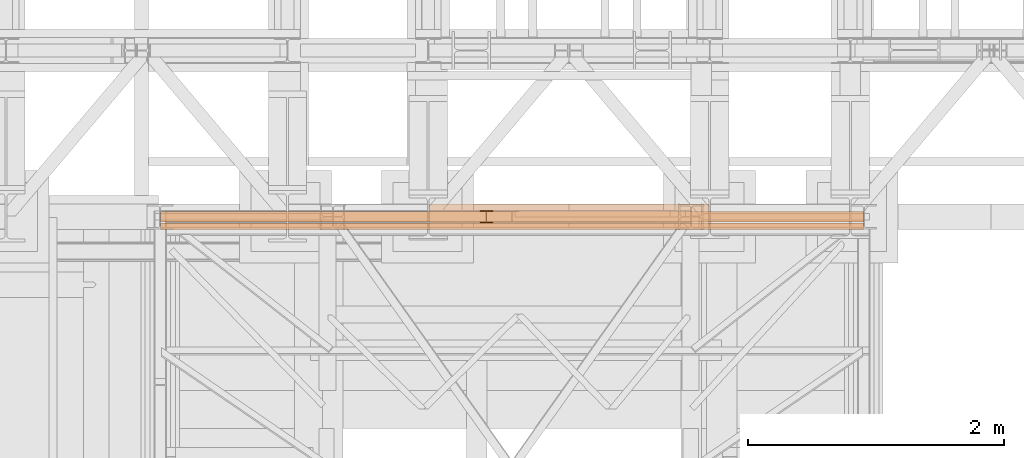
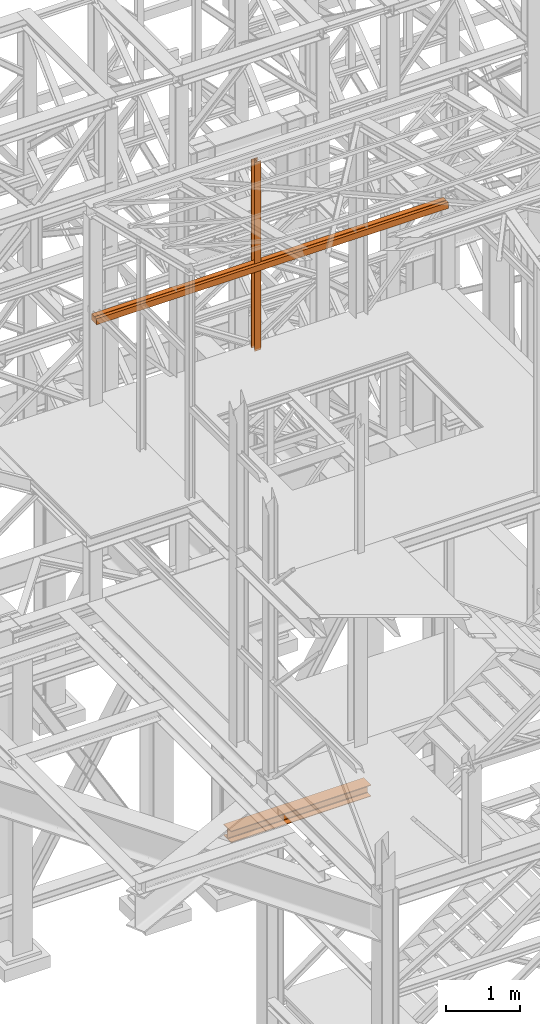
# One storey, part 70 of 208: 5 proxies.
"""IFC2X3 building model written with IfcOpenShell, lengths in millimetres."""

from ifc_helpers import new_model, entity, si_unit, converted_unit, frame, origin, origin_with_axes, place, context, subcontext, project, spatial, faceted_brep, element, save


model = new_model("IFC2X3")

# Units and contexts
model_context = context("Model", 3, precision=1e-05, world=origin())
plan_context = context("Plan", 3, precision=1e-05, world=origin())
body_context = subcontext(model_context, "Body", "Model", "MODEL_VIEW")
ifc_project = project(units=[si_unit("LENGTHUNIT", "METRE", prefix="MILLI"), converted_unit("PLANEANGLEUNIT", "DEGREE", entity("IfcPlaneAngleMeasure", 0.0174532925199433), si_unit("PLANEANGLEUNIT", "RADIAN"), dimensions=[0, 0, 0, 0, 0, 0, 0]), si_unit("AREAUNIT", "SQUARE_METRE"), si_unit("VOLUMEUNIT", "CUBIC_METRE")], contexts=[model_context, plan_context])

# Building, storey
building_placement = place(None, origin())
building = spatial("IfcBuilding", under=ifc_project, at=building_placement, CompositionType="COMPLEX")
storey_placement = place(building_placement, origin_with_axes())
storey = spatial("IfcBuildingStorey", under=building, at=storey_placement, Name="Geschoss", CompositionType="ELEMENT")

# Proxies
proxy_1_placement = place(storey_placement, frame((3698.25496852866, -17310.57439031789, 8484.990002086157), z_axis=(0.0, 0.0, 1.0), x_axis=(1.0, 0.0, 0.0)))
element("IfcBuildingElementProxy", 1, at=proxy_1_placement, inside=storey, context=body_context, shape_type="Brep", body=[
    faceted_brep([(100.010000000002, 88.0099999999984, 0.01000000000021828), (100.010000000002, 96.0099999999984, 0.01000000000021828), (0.01000000000203727, 96.0099999999984, 0.01000000000021828), (0.01000000000203727, 88.0099999999984, 0.01000000000021828), (47.51000000000204, 88.0099999999984, 0.01000000000021828), (47.51000000000204, 8.0099999999984, 0.01000000000021828), (0.01000000000203727, 8.0099999999984, 0.01000000000021828), (0.01000000000203727, 0.00999999999839929, 0.01000000000021828), (100.010000000002, 0.00999999999839929, 0.01000000000021828), (100.010000000002, 8.0099999999984, 0.01000000000021828), (52.51000000000204, 8.0099999999984, 0.01000000000021828), (52.51000000000204, 88.0099999999984, 0.01000000000021828), (100.010000000002, 96.0099999999984, 0.01000000000021828), (100.010000000002, 88.0099999999984, 0.01000000000021828), (100.0100000000002, 88.0099999999984, 3115.009992251404), (100.0100000000002, 96.0099999999984, 3115.009992251404), (0.01000000000203727, 96.0099999999984, 0.01000000000021828), (100.010000000002, 96.0099999999984, 0.01000000000021828), (100.0100000000002, 96.0099999999984, 3115.009992251404), (0.01000000000021828, 96.0099999999984, 3115.009992251404), (0.01000000000203727, 88.0099999999984, 0.01000000000021828), (0.01000000000203727, 96.0099999999984, 0.01000000000021828), (0.01000000000021828, 96.0099999999984, 3115.009992251404), (0.01000000000021828, 88.0099999999984, 3115.009992251404), (47.51000000000204, 88.0099999999984, 0.01000000000021828), (0.01000000000203727, 88.0099999999984, 0.01000000000021828), (0.01000000000021828, 88.0099999999984, 3115.009992251404), (47.51000000000022, 88.0099999999984, 3115.009992251404), (47.51000000000204, 8.0099999999984, 0.01000000000021828), (47.51000000000204, 88.0099999999984, 0.01000000000021828), (47.51000000000022, 88.0099999999984, 3115.009992251404), (47.51000000000022, 8.0099999999984, 3115.009992251404), (0.01000000000203727, 8.0099999999984, 0.01000000000021828), (47.51000000000204, 8.0099999999984, 0.01000000000021828), (47.51000000000022, 8.0099999999984, 3115.009992251404), (0.01000000000021828, 8.0099999999984, 3115.009992251404), (0.01000000000203727, 0.00999999999839929, 0.01000000000021828), (0.01000000000203727, 8.0099999999984, 0.01000000000021828), (0.01000000000021828, 8.0099999999984, 3115.009992251404), (0.01000000000021828, 0.00999999999839929, 3115.009992251404), (100.010000000002, 0.00999999999839929, 0.01000000000021828), (0.01000000000203727, 0.00999999999839929, 0.01000000000021828), (0.01000000000021828, 0.00999999999839929, 3115.009992251404), (100.0100000000002, 0.00999999999839929, 3115.009992251404), (100.010000000002, 8.0099999999984, 0.01000000000021828), (100.010000000002, 0.00999999999839929, 0.01000000000021828), (100.0100000000002, 0.00999999999839929, 3115.009992251404), (100.0100000000002, 8.0099999999984, 3115.009992251404), (52.51000000000204, 8.0099999999984, 0.01000000000021828), (100.010000000002, 8.0099999999984, 0.01000000000021828), (100.0100000000002, 8.0099999999984, 3115.009992251404), (52.51000000000022, 8.0099999999984, 3115.009992251404), (52.51000000000204, 88.0099999999984, 0.01000000000021828), (52.51000000000204, 8.0099999999984, 0.01000000000021828), (52.51000000000022, 8.0099999999984, 3115.009992251404), (52.51000000000022, 88.0099999999984, 3115.009992251404), (100.010000000002, 88.0099999999984, 0.01000000000021828), (52.51000000000204, 88.0099999999984, 0.01000000000021828), (52.51000000000022, 88.0099999999984, 3115.009992251404), (100.0100000000002, 88.0099999999984, 3115.009992251404), (100.0100000000002, 88.0099999999984, 3115.009992251404), (52.51000000000022, 88.0099999999984, 3115.009992251404), (52.51000000000022, 8.0099999999984, 3115.009992251404), (100.0100000000002, 8.0099999999984, 3115.009992251404), (100.0100000000002, 0.00999999999839929, 3115.009992251404), (0.01000000000021828, 0.00999999999839929, 3115.009992251404), (0.01000000000021828, 8.0099999999984, 3115.009992251404), (47.51000000000022, 8.0099999999984, 3115.009992251404), (47.51000000000022, 88.0099999999984, 3115.009992251404), (0.01000000000021828, 88.0099999999984, 3115.009992251404), (0.01000000000021828, 96.0099999999984, 3115.009992251404), (100.0100000000002, 96.0099999999984, 3115.009992251404)], [[[0, 1, 2, 3, 4, 5, 6, 7, 8, 9, 10, 11]], [[12, 13, 14, 15]], [[16, 17, 18, 19]], [[20, 21, 22, 23]], [[24, 25, 26, 27]], [[28, 29, 30, 31]], [[32, 33, 34, 35]], [[36, 37, 38, 39]], [[40, 41, 42, 43]], [[44, 45, 46, 47]], [[48, 49, 50, 51]], [[52, 53, 54, 55]], [[56, 57, 58, 59]], [[60, 61, 62, 63, 64, 65, 66, 67, 68, 69, 70, 71]]], orient=[[False], [False], [False], [False], [False], [False], [False], [False], [False], [False], [False], [False], [False], [False]]),
])
proxy_2_placement = place(storey_placement, frame((1201.504968595714, -17362.574391808, 9829.990000745052), z_axis=(0.0, 0.0, 1.0), x_axis=(1.0, 0.0, 0.0)))
element("IfcBuildingElementProxy", 2, at=proxy_2_placement, inside=storey, context=body_context, shape_type="Brep", body=[
    faceted_brep([(0.01000000000021828, 140.0100014901145, 0.01000000000021828), (0.01000000000021828, 60.01000149011452, 0.01000000000021828), (0.01000000000021828, 60.01000149011452, 47.51000000000022), (0.01000000000021828, 140.0100014901145, 47.51000000000022), (0.01000000000021828, 52.01000149011452, 0.01000000000021828), (0.01000000000021828, 0.01000000000203727, 0.01001766269655491), (0.01000000000021828, 0.01000000000203727, 100.0100176626966), (0.01000000000021828, 52.01000149011452, 100.0100000000002), (0.01000000000021828, 60.01000149011452, 100.0100000000002), (0.01000000000021828, 140.0100014901145, 100.0100000000002), (0.01000000000021828, 140.0100014901145, 52.51000000000022), (0.01000000000021828, 60.01000149011452, 52.51000000000022), (0.01000000000021828, 0.01000000000203727, 0.01001766269655491), (0.01000000000021828, 52.01000149011452, 0.01000000000021828), (5493.509999865888, 52.01000149011452, 0.01001110226570745), (5493.509999865888, 0.01000000000203727, 0.01001766269655491), (0.01000000000021828, 0.01000000000203727, 100.0100176626966), (0.01000000000021828, 0.01000000000203727, 0.01001766269655491), (5493.509999865888, 0.01000000000203727, 0.01001766269655491), (5493.509999865888, 0.01000000000203727, 100.0100176626966), (0.01000000000021828, 140.0100014901145, 100.0100000000002), (0.01000000000021828, 60.01000149011452, 100.0100000000002), (5493.509999865888, 60.01000149011452, 100.0100100929703), (5493.509999865888, 140.0100014901145, 100.0100000000002), (0.01000000000021828, 140.0100014901145, 52.51000000000022), (0.01000000000021828, 140.0100014901145, 100.0100000000002), (5493.509999865888, 140.0100014901145, 100.0100000000002), (5493.509999865888, 140.0100014901145, 52.51000000000022), (0.01000000000021828, 60.01000149011452, 52.51000000000022), (0.01000000000021828, 140.0100014901145, 52.51000000000022), (5493.509999865888, 140.0100014901145, 52.51000000000022), (5493.509999865888, 60.01000149011452, 52.51000000000022), (0.01000000000021828, 60.01000149011452, 100.0100000000002), (0.01000000000021828, 60.01000149011452, 52.51000000000022), (5493.509999865888, 60.01000149011452, 52.51000000000022), (5493.509999865888, 60.01000149011452, 100.0100100929703), (0.01000000000021828, 52.01000149011452, 0.01000000000021828), (0.01000000000021828, 52.01000149011452, 100.0100000000002), (5493.509999865888, 52.01000149011452, 100.0100000000002), (5493.509999865888, 52.01000149011452, 0.01001110226570745), (0.01000000000021828, 60.01000149011452, 47.51000000000022), (0.01000000000021828, 60.01000149011452, 0.01000000000021828), (5493.509999865888, 60.01000149011452, 0.01000000000021828), (5493.509999865888, 60.01000149011452, 47.51000000000022), (0.01000000000021828, 140.0100014901145, 47.51000000000022), (0.01000000000021828, 60.01000149011452, 47.51000000000022), (5493.509999865888, 60.01000149011452, 47.51000000000022), (5493.509999865888, 140.0100014901145, 47.51000000000022), (0.01000000000021828, 140.0100014901145, 0.01000000000021828), (0.01000000000021828, 140.0100014901145, 47.51000000000022), (5493.509999865888, 140.0100014901145, 47.51000000000022), (5493.509999865888, 140.0100014901145, 0.01000000000021828), (5493.509999865888, 140.0100014901145, 0.01000000000021828), (5493.509999865888, 140.0100014901145, 47.51000000000022), (5493.509999865888, 60.01000149011452, 47.51000000000022), (5493.509999865888, 60.01000149011452, 0.01000000000021828), (5493.509999865888, 52.01000149011452, 0.01001110226570745), (5493.509999865888, 52.01000149011452, 100.0100000000002), (5493.509999865888, 0.01000000000203727, 100.0100176626966), (5493.509999865888, 0.01000000000203727, 0.01001766269655491), (5493.509999865888, 60.01000149011452, 100.0100100929703), (5493.509999865888, 60.01000149011452, 52.51000000000022), (5493.509999865888, 140.0100014901145, 52.51000000000022), (5493.509999865888, 140.0100014901145, 100.0100000000002), (0.01000000000021828, 60.01000149011452, 0.01000000000021828), (0.01000000000021828, 140.0100014901145, 0.01000000000021828), (5493.509999865888, 140.0100014901145, 0.01000000000021828), (5493.509999865888, 60.01000149011452, 0.01000000000021828), (0.01000000000021828, 52.01000149011452, 100.0100000000002), (0.01000000000021828, 0.01000000000203727, 100.0100176626966), (5493.509999865888, 0.01000000000203727, 100.0100176626966), (5493.509999865888, 52.01000149011452, 100.0100000000002)], [[[0, 1, 2, 3], [4, 5, 6, 7], [8, 9, 10, 11]], [[12, 13, 14, 15]], [[16, 17, 18, 19]], [[20, 21, 22, 23]], [[24, 25, 26, 27]], [[28, 29, 30, 31]], [[32, 33, 34, 35]], [[36, 37, 38, 39]], [[40, 41, 42, 43]], [[44, 45, 46, 47]], [[48, 49, 50, 51]], [[52, 53, 54, 55], [56, 57, 58, 59], [60, 61, 62, 63]], [[64, 65, 66, 67]], [[68, 69, 70, 71]]], orient=[[False, False, False], [False], [False], [False], [False], [False], [False], [False], [False], [False], [False], [False, False, False], [False], [False]], outer=[[True, True, True], [True], [True], [True], [True], [True], [True], [True], [True], [True], [True], [True, True, True], [True], [True]]),
])
proxy_3_placement = place(storey_placement, frame((3698.25496852866, -17310.57439031789, 8484.990002086157), z_axis=(0.0, 0.0, 1.0), x_axis=(1.0, 0.0, 0.0)))
element("IfcBuildingElementProxy", 3, at=proxy_3_placement, inside=storey, context=body_context, shape_type="Brep", body=[
    faceted_brep([(100.010000000002, 88.0099999999984, 0.01000000000021828), (100.010000000002, 96.0099999999984, 0.01000000000021828), (0.01000000000203727, 96.0099999999984, 0.01000000000021828), (0.01000000000203727, 88.0099999999984, 0.01000000000021828), (47.51000000000204, 88.0099999999984, 0.01000000000021828), (47.51000000000204, 8.0099999999984, 0.01000000000021828), (0.01000000000203727, 8.0099999999984, 0.01000000000021828), (0.01000000000203727, 0.00999999999839929, 0.01000000000021828), (100.010000000002, 0.00999999999839929, 0.01000000000021828), (100.010000000002, 8.0099999999984, 0.01000000000021828), (52.51000000000204, 8.0099999999984, 0.01000000000021828), (52.51000000000204, 88.0099999999984, 0.01000000000021828), (100.010000000002, 96.0099999999984, 0.01000000000021828), (100.010000000002, 88.0099999999984, 0.01000000000021828), (100.0100000000002, 88.0099999999984, 3115.009992251404), (100.0100000000002, 96.0099999999984, 3115.009992251404), (0.01000000000203727, 96.0099999999984, 0.01000000000021828), (100.010000000002, 96.0099999999984, 0.01000000000021828), (100.0100000000002, 96.0099999999984, 3115.009992251404), (0.01000000000021828, 96.0099999999984, 3115.009992251404), (0.01000000000203727, 88.0099999999984, 0.01000000000021828), (0.01000000000203727, 96.0099999999984, 0.01000000000021828), (0.01000000000021828, 96.0099999999984, 3115.009992251404), (0.01000000000021828, 88.0099999999984, 3115.009992251404), (47.51000000000204, 88.0099999999984, 0.01000000000021828), (0.01000000000203727, 88.0099999999984, 0.01000000000021828), (0.01000000000021828, 88.0099999999984, 3115.009992251404), (47.51000000000022, 88.0099999999984, 3115.009992251404), (47.51000000000204, 8.0099999999984, 0.01000000000021828), (47.51000000000204, 88.0099999999984, 0.01000000000021828), (47.51000000000022, 88.0099999999984, 3115.009992251404), (47.51000000000022, 8.0099999999984, 3115.009992251404), (0.01000000000203727, 8.0099999999984, 0.01000000000021828), (47.51000000000204, 8.0099999999984, 0.01000000000021828), (47.51000000000022, 8.0099999999984, 3115.009992251404), (0.01000000000021828, 8.0099999999984, 3115.009992251404), (0.01000000000203727, 0.00999999999839929, 0.01000000000021828), (0.01000000000203727, 8.0099999999984, 0.01000000000021828), (0.01000000000021828, 8.0099999999984, 3115.009992251404), (0.01000000000021828, 0.00999999999839929, 3115.009992251404), (100.010000000002, 0.00999999999839929, 0.01000000000021828), (0.01000000000203727, 0.00999999999839929, 0.01000000000021828), (0.01000000000021828, 0.00999999999839929, 3115.009992251404), (100.0100000000002, 0.00999999999839929, 3115.009992251404), (100.010000000002, 8.0099999999984, 0.01000000000021828), (100.010000000002, 0.00999999999839929, 0.01000000000021828), (100.0100000000002, 0.00999999999839929, 3115.009992251404), (100.0100000000002, 8.0099999999984, 3115.009992251404), (52.51000000000204, 8.0099999999984, 0.01000000000021828), (100.010000000002, 8.0099999999984, 0.01000000000021828), (100.0100000000002, 8.0099999999984, 3115.009992251404), (52.51000000000022, 8.0099999999984, 3115.009992251404), (52.51000000000204, 88.0099999999984, 0.01000000000021828), (52.51000000000204, 8.0099999999984, 0.01000000000021828), (52.51000000000022, 8.0099999999984, 3115.009992251404), (52.51000000000022, 88.0099999999984, 3115.009992251404), (100.010000000002, 88.0099999999984, 0.01000000000021828), (52.51000000000204, 88.0099999999984, 0.01000000000021828), (52.51000000000022, 88.0099999999984, 3115.009992251404), (100.0100000000002, 88.0099999999984, 3115.009992251404), (100.0100000000002, 88.0099999999984, 3115.009992251404), (52.51000000000022, 88.0099999999984, 3115.009992251404), (52.51000000000022, 8.0099999999984, 3115.009992251404), (100.0100000000002, 8.0099999999984, 3115.009992251404), (100.0100000000002, 0.00999999999839929, 3115.009992251404), (0.01000000000021828, 0.00999999999839929, 3115.009992251404), (0.01000000000021828, 8.0099999999984, 3115.009992251404), (47.51000000000022, 8.0099999999984, 3115.009992251404), (47.51000000000022, 88.0099999999984, 3115.009992251404), (0.01000000000021828, 88.0099999999984, 3115.009992251404), (0.01000000000021828, 96.0099999999984, 3115.009992251404), (100.0100000000002, 96.0099999999984, 3115.009992251404)], [[[0, 1, 2, 3, 4, 5, 6, 7, 8, 9, 10, 11]], [[12, 13, 14, 15]], [[16, 17, 18, 19]], [[20, 21, 22, 23]], [[24, 25, 26, 27]], [[28, 29, 30, 31]], [[32, 33, 34, 35]], [[36, 37, 38, 39]], [[40, 41, 42, 43]], [[44, 45, 46, 47]], [[48, 49, 50, 51]], [[52, 53, 54, 55]], [[56, 57, 58, 59]], [[60, 61, 62, 63, 64, 65, 66, 67, 68, 69, 70, 71]]], orient=[[False], [False], [False], [False], [False], [False], [False], [False], [False], [False], [False], [False], [False], [False]]),
])
proxy_4_placement = place(storey_placement, frame((1201.504968595714, -17362.574391808, 9829.990000745052), z_axis=(0.0, 0.0, 1.0), x_axis=(1.0, 0.0, 0.0)))
element("IfcBuildingElementProxy", 4, at=proxy_4_placement, inside=storey, context=body_context, shape_type="Brep", body=[
    faceted_brep([(0.01000000000021828, 140.0100014901145, 0.01000000000021828), (0.01000000000021828, 60.01000149011452, 0.01000000000021828), (0.01000000000021828, 60.01000149011452, 47.51000000000022), (0.01000000000021828, 140.0100014901145, 47.51000000000022), (0.01000000000021828, 52.01000149011452, 0.01000000000021828), (0.01000000000021828, 0.01000000000203727, 0.01001766269655491), (0.01000000000021828, 0.01000000000203727, 100.0100176626966), (0.01000000000021828, 52.01000149011452, 100.0100000000002), (0.01000000000021828, 60.01000149011452, 100.0100000000002), (0.01000000000021828, 140.0100014901145, 100.0100000000002), (0.01000000000021828, 140.0100014901145, 52.51000000000022), (0.01000000000021828, 60.01000149011452, 52.51000000000022), (0.01000000000021828, 0.01000000000203727, 0.01001766269655491), (0.01000000000021828, 52.01000149011452, 0.01000000000021828), (5493.509999865888, 52.01000149011452, 0.01001110226570745), (5493.509999865888, 0.01000000000203727, 0.01001766269655491), (0.01000000000021828, 0.01000000000203727, 100.0100176626966), (0.01000000000021828, 0.01000000000203727, 0.01001766269655491), (5493.509999865888, 0.01000000000203727, 0.01001766269655491), (5493.509999865888, 0.01000000000203727, 100.0100176626966), (0.01000000000021828, 140.0100014901145, 100.0100000000002), (0.01000000000021828, 60.01000149011452, 100.0100000000002), (5493.509999865888, 60.01000149011452, 100.0100100929703), (5493.509999865888, 140.0100014901145, 100.0100000000002), (0.01000000000021828, 140.0100014901145, 52.51000000000022), (0.01000000000021828, 140.0100014901145, 100.0100000000002), (5493.509999865888, 140.0100014901145, 100.0100000000002), (5493.509999865888, 140.0100014901145, 52.51000000000022), (0.01000000000021828, 60.01000149011452, 52.51000000000022), (0.01000000000021828, 140.0100014901145, 52.51000000000022), (5493.509999865888, 140.0100014901145, 52.51000000000022), (5493.509999865888, 60.01000149011452, 52.51000000000022), (0.01000000000021828, 60.01000149011452, 100.0100000000002), (0.01000000000021828, 60.01000149011452, 52.51000000000022), (5493.509999865888, 60.01000149011452, 52.51000000000022), (5493.509999865888, 60.01000149011452, 100.0100100929703), (0.01000000000021828, 52.01000149011452, 0.01000000000021828), (0.01000000000021828, 52.01000149011452, 100.0100000000002), (5493.509999865888, 52.01000149011452, 100.0100000000002), (5493.509999865888, 52.01000149011452, 0.01001110226570745), (0.01000000000021828, 60.01000149011452, 47.51000000000022), (0.01000000000021828, 60.01000149011452, 0.01000000000021828), (5493.509999865888, 60.01000149011452, 0.01000000000021828), (5493.509999865888, 60.01000149011452, 47.51000000000022), (0.01000000000021828, 140.0100014901145, 47.51000000000022), (0.01000000000021828, 60.01000149011452, 47.51000000000022), (5493.509999865888, 60.01000149011452, 47.51000000000022), (5493.509999865888, 140.0100014901145, 47.51000000000022), (0.01000000000021828, 140.0100014901145, 0.01000000000021828), (0.01000000000021828, 140.0100014901145, 47.51000000000022), (5493.509999865888, 140.0100014901145, 47.51000000000022), (5493.509999865888, 140.0100014901145, 0.01000000000021828), (5493.509999865888, 140.0100014901145, 0.01000000000021828), (5493.509999865888, 140.0100014901145, 47.51000000000022), (5493.509999865888, 60.01000149011452, 47.51000000000022), (5493.509999865888, 60.01000149011452, 0.01000000000021828), (5493.509999865888, 52.01000149011452, 0.01001110226570745), (5493.509999865888, 52.01000149011452, 100.0100000000002), (5493.509999865888, 0.01000000000203727, 100.0100176626966), (5493.509999865888, 0.01000000000203727, 0.01001766269655491), (5493.509999865888, 60.01000149011452, 100.0100100929703), (5493.509999865888, 60.01000149011452, 52.51000000000022), (5493.509999865888, 140.0100014901145, 52.51000000000022), (5493.509999865888, 140.0100014901145, 100.0100000000002), (0.01000000000021828, 60.01000149011452, 0.01000000000021828), (0.01000000000021828, 140.0100014901145, 0.01000000000021828), (5493.509999865888, 140.0100014901145, 0.01000000000021828), (5493.509999865888, 60.01000149011452, 0.01000000000021828), (0.01000000000021828, 52.01000149011452, 100.0100000000002), (0.01000000000021828, 0.01000000000203727, 100.0100176626966), (5493.509999865888, 0.01000000000203727, 100.0100176626966), (5493.509999865888, 52.01000149011452, 100.0100000000002)], [[[0, 1, 2, 3], [4, 5, 6, 7], [8, 9, 10, 11]], [[12, 13, 14, 15]], [[16, 17, 18, 19]], [[20, 21, 22, 23]], [[24, 25, 26, 27]], [[28, 29, 30, 31]], [[32, 33, 34, 35]], [[36, 37, 38, 39]], [[40, 41, 42, 43]], [[44, 45, 46, 47]], [[48, 49, 50, 51]], [[52, 53, 54, 55], [56, 57, 58, 59], [60, 61, 62, 63]], [[64, 65, 66, 67]], [[68, 69, 70, 71]]], orient=[[False, False, False], [False], [False], [False], [False], [False], [False], [False], [False], [False], [False], [False, False, False], [False], [False]], outer=[[True, True, True], [True], [True], [True], [True], [True], [True], [True], [True], [True], [True], [True, True, True], [True], [True]]),
])
proxy_5_placement = place(storey_placement, frame((3300.004974593443, -17362.5323246858, 544.9900024165573), z_axis=(0.0, 0.0, 1.0), x_axis=(1.0, 0.0, 0.0)))
element("IfcBuildingElementProxy", 5, at=proxy_5_placement, inside=storey, context=body_context, shape_type="Brep", body=[
    faceted_brep([(2188.009999895689, 0.00999999999839929, 190.0100125169756), (2188.009999895689, 200.0100029802306, 190.0100125169756), (2188.009999895689, 200.0100029802306, 180.0100146031382), (2188.009999895689, 121.2600035762771, 180.0100071525576), (2188.009999895689, 111.9441915473326, 178.1454621052744), (2188.009999895689, 105.1245498640819, 171.3258190250399), (2188.009999895689, 103.2600015571697, 162.010007927418), (2188.009999895689, 103.2600015571697, 28.00999713897727), (2188.009999895689, 105.1245498640819, 18.69418604135535), (2188.009999895689, 111.9441915473326, 11.87454296112082), (2188.009999895689, 121.2600035762771, 10.00999791383765), (2188.009999895689, 200.0100029802306, 10.00999791383765), (2188.009999895689, 200.0100029802306, 0.01000000000021828), (2188.009999895689, 0.00999999999839929, 0.01000000000021828), (2188.009999895689, 0.00999999999839929, 10.00999791383765), (2188.009999895689, 78.75999940395195, 10.00999791383765), (2188.009999895689, 88.07581143289644, 11.87454296112082), (2188.009999895689, 94.89545311614711, 18.69418604135535), (2188.009999895689, 96.7600014230593, 28.00999713897727), (2188.009999895689, 96.7600014230593, 162.010007927418), (2188.009999895689, 94.89545311614711, 171.3258190250399), (2188.009999895689, 88.07581143289644, 178.1454621052744), (2188.009999895689, 78.75999940395195, 180.0100071525576), (2188.009999895689, 0.00999999999839929, 180.0100146031382), (2188.009999895689, 200.0100029802306, 190.0100125169756), (2188.009999895689, 0.00999999999839929, 190.0100125169756), (0.009999999999308784, 0.01000000000203727, 190.0100125169755), (0.009999999999308784, 200.0100029802343, 190.0100125169755), (2188.009999895689, 200.0100029802306, 180.0100146031382), (2188.009999895689, 200.0100029802306, 190.0100125169756), (0.009999999999308784, 200.0100029802343, 190.0100125169755), (0.009999999999308784, 200.0100029802343, 180.0100146031381), (2188.009999895689, 121.2600035762771, 180.0100071525576), (2188.009999895689, 200.0100029802306, 180.0100146031382), (0.009999999999308784, 200.0100029802343, 180.0100146031381), (0.009999999999308784, 121.2600035762807, 180.0100071525575), (2188.009999895689, 111.9441915473326, 178.1454621052744), (2188.009999895689, 121.2600035762771, 180.0100071525576), (0.009999999999308784, 121.2600035762807, 180.0100071525575), (0.009999999999308784, 111.9441915473362, 178.1454621052743), (2188.009999895689, 105.1245498640819, 171.3258190250399), (2188.009999895689, 111.9441915473326, 178.1454621052744), (0.009999999999308784, 111.9441915473362, 178.1454621052743), (0.009999999999308784, 105.1245498640856, 171.3258190250398), (2188.009999895689, 103.2600015571697, 162.010007927418), (2188.009999895689, 105.1245498640819, 171.3258190250399), (0.009999999999308784, 105.1245498640856, 171.3258190250398), (0.009999999999308784, 103.2600015571734, 162.0100079274179), (2188.009999895689, 103.2600015571697, 28.00999713897727), (2188.009999895689, 103.2600015571697, 162.010007927418), (0.009999999999308784, 103.2600015571734, 162.0100079274179), (0.009999999999308784, 103.2600015571734, 28.00999713897716), (2188.009999895689, 105.1245498640819, 18.69418604135535), (2188.009999895689, 103.2600015571697, 28.00999713897727), (0.009999999999308784, 103.2600015571734, 28.00999713897716), (0.009999999999308784, 105.1245498640856, 18.69418604135524), (2188.009999895689, 111.9441915473326, 11.87454296112082), (2188.009999895689, 105.1245498640819, 18.69418604135535), (0.009999999999308784, 105.1245498640856, 18.69418604135524), (0.009999999999308784, 111.9441915473362, 11.87454296112071), (2188.009999895689, 121.2600035762771, 10.00999791383765), (2188.009999895689, 111.9441915473326, 11.87454296112082), (0.009999999999308784, 111.9441915473362, 11.87454296112071), (0.009999999999308784, 121.2600035762807, 10.00999791383754), (2188.009999895689, 200.0100029802306, 10.00999791383765), (2188.009999895689, 121.2600035762771, 10.00999791383765), (0.009999999999308784, 121.2600035762807, 10.00999791383754), (0.009999999999308784, 200.0100029802343, 10.00999791383754), (2188.009999895689, 200.0100029802306, 0.01000000000021828), (2188.009999895689, 200.0100029802306, 10.00999791383765), (0.009999999999308784, 200.0100029802343, 10.00999791383754), (0.009999999999308784, 200.0100029802343, 0.01000000000010459), (2188.009999895689, 0.00999999999839929, 0.01000000000021828), (2188.009999895689, 200.0100029802306, 0.01000000000021828), (0.009999999999308784, 200.0100029802343, 0.01000000000010459), (0.009999999999308784, 0.01000000000203727, 0.01000000000010459), (2188.009999895689, 0.00999999999839929, 10.00999791383765), (2188.009999895689, 0.00999999999839929, 0.01000000000021828), (0.009999999999308784, 0.01000000000203727, 0.01000000000010459), (0.009999999999308784, 0.01000000000203727, 10.00999791383754), (2188.009999895689, 78.75999940395195, 10.00999791383765), (2188.009999895689, 0.00999999999839929, 10.00999791383765), (0.009999999999308784, 0.01000000000203727, 10.00999791383754), (0.009999999999308784, 78.75999940395559, 10.00999791383754), (2188.009999895689, 88.07581143289644, 11.87454296112082), (2188.009999895689, 78.75999940395195, 10.00999791383765), (0.009999999999308784, 78.75999940395559, 10.00999791383754), (0.009999999999308784, 88.07581143290008, 11.87454296112071), (2188.009999895689, 94.89545311614711, 18.69418604135535), (2188.009999895689, 88.07581143289644, 11.87454296112082), (0.009999999999308784, 88.07581143290008, 11.87454296112071), (0.009999999999308784, 94.89545311615075, 18.69418604135524), (2188.009999895689, 96.7600014230593, 28.00999713897727), (2188.009999895689, 94.89545311614711, 18.69418604135535), (0.009999999999308784, 94.89545311615075, 18.69418604135524), (0.009999999999308784, 96.76000142306293, 28.00999713897716), (2188.009999895689, 96.7600014230593, 162.010007927418), (2188.009999895689, 96.7600014230593, 28.00999713897727), (0.009999999999308784, 96.76000142306293, 28.00999713897716), (0.009999999999308784, 96.76000142306293, 162.0100079274179), (2188.009999895689, 94.89545311614711, 171.3258190250399), (2188.009999895689, 96.7600014230593, 162.010007927418), (0.009999999999308784, 96.76000142306293, 162.0100079274179), (0.009999999999308784, 94.89545311615075, 171.3258190250398), (2188.009999895689, 88.07581143289644, 178.1454621052744), (2188.009999895689, 94.89545311614711, 171.3258190250399), (0.009999999999308784, 94.89545311615075, 171.3258190250398), (0.009999999999308784, 88.07581143290008, 178.1454621052743), (2188.009999895689, 78.75999940395195, 180.0100071525576), (2188.009999895689, 88.07581143289644, 178.1454621052744), (0.009999999999308784, 88.07581143290008, 178.1454621052743), (0.009999999999308784, 78.75999940395559, 180.0100071525575), (2188.009999895689, 0.00999999999839929, 180.0100146031382), (2188.009999895689, 78.75999940395195, 180.0100071525576), (0.009999999999308784, 78.75999940395559, 180.0100071525575), (0.009999999999308784, 0.01000000000203727, 180.0100146031381), (2188.009999895689, 0.00999999999839929, 190.0100125169756), (2188.009999895689, 0.00999999999839929, 180.0100146031382), (0.009999999999308784, 0.01000000000203727, 180.0100146031381), (0.009999999999308784, 0.01000000000203727, 190.0100125169755), (0.009999999999308784, 0.01000000000203727, 190.0100125169755), (0.009999999999308784, 0.01000000000203727, 180.0100146031381), (0.009999999999308784, 78.75999940395559, 180.0100071525575), (0.009999999999308784, 88.07581143290008, 178.1454621052743), (0.009999999999308784, 94.89545311615075, 171.3258190250398), (0.009999999999308784, 96.76000142306293, 162.0100079274179), (0.009999999999308784, 96.76000142306293, 28.00999713897716), (0.009999999999308784, 94.89545311615075, 18.69418604135524), (0.009999999999308784, 88.07581143290008, 11.87454296112071), (0.009999999999308784, 78.75999940395559, 10.00999791383754), (0.009999999999308784, 0.01000000000203727, 10.00999791383754), (0.009999999999308784, 0.01000000000203727, 0.01000000000010459), (0.009999999999308784, 200.0100029802343, 0.01000000000010459), (0.009999999999308784, 200.0100029802343, 10.00999791383754), (0.009999999999308784, 121.2600035762807, 10.00999791383754), (0.009999999999308784, 111.9441915473362, 11.87454296112071), (0.009999999999308784, 105.1245498640856, 18.69418604135524), (0.009999999999308784, 103.2600015571734, 28.00999713897716), (0.009999999999308784, 103.2600015571734, 162.0100079274179), (0.009999999999308784, 105.1245498640856, 171.3258190250398), (0.009999999999308784, 111.9441915473362, 178.1454621052743), (0.009999999999308784, 121.2600035762807, 180.0100071525575), (0.009999999999308784, 200.0100029802343, 180.0100146031381), (0.009999999999308784, 200.0100029802343, 190.0100125169755)], [[[0, 1, 2, 3, 4, 5, 6, 7, 8, 9, 10, 11, 12, 13, 14, 15, 16, 17, 18, 19, 20, 21, 22, 23]], [[24, 25, 26, 27]], [[28, 29, 30, 31]], [[32, 33, 34, 35]], [[36, 37, 38, 39]], [[40, 41, 42, 43]], [[44, 45, 46, 47]], [[48, 49, 50, 51]], [[52, 53, 54, 55]], [[56, 57, 58, 59]], [[60, 61, 62, 63]], [[64, 65, 66, 67]], [[68, 69, 70, 71]], [[72, 73, 74, 75]], [[76, 77, 78, 79]], [[80, 81, 82, 83]], [[84, 85, 86, 87]], [[88, 89, 90, 91]], [[92, 93, 94, 95]], [[96, 97, 98, 99]], [[100, 101, 102, 103]], [[104, 105, 106, 107]], [[108, 109, 110, 111]], [[112, 113, 114, 115]], [[116, 117, 118, 119]], [[120, 121, 122, 123, 124, 125, 126, 127, 128, 129, 130, 131, 132, 133, 134, 135, 136, 137, 138, 139, 140, 141, 142, 143]]], orient=[[False], [False], [False], [False], [False], [False], [False], [False], [False], [False], [False], [False], [False], [False], [False], [False], [False], [False], [False], [False], [False], [False], [False], [False], [False], [False]]),
])

save(model, "model.ifc")
